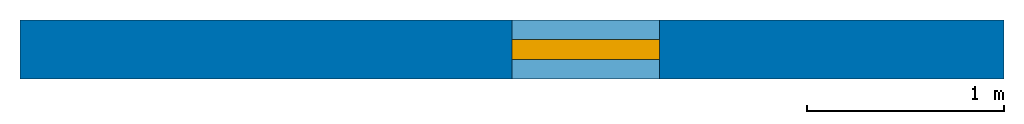
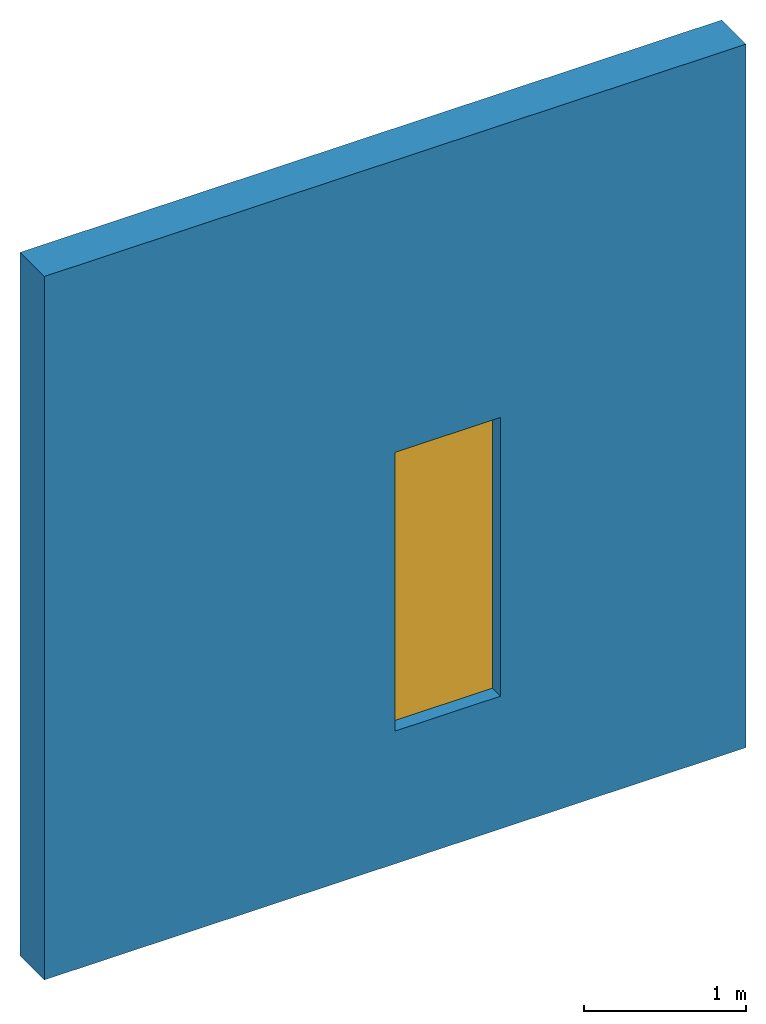
# One storey: 1 door, 1 wall, 1 opening.
"""IFC2X3 model written with IfcOpenShell, lengths in metres."""

from ifc_helpers import new_model, entity, si_unit, converted_unit, frame, origin, origin_with_axes, place, context, project, spatial, polyline, outline, extrude, material, layer, layer_set, layer_usage, element, fill, save


model = new_model("IFC2X3")

# Units and contexts
model_context = context("Model", 3, precision=1e-05, world=origin())
ifc_project = project(units=[si_unit("LENGTHUNIT", "METRE"), si_unit("AREAUNIT", "SQUARE_METRE"), si_unit("VOLUMEUNIT", "CUBIC_METRE"), converted_unit("PLANEANGLEUNIT", "DEGREE", entity("IfcPlaneAngleMeasure", 0.01745), si_unit("PLANEANGLEUNIT", "RADIAN"), dimensions=[0, 0, 0, 0, 0, 0, 0]), si_unit("SOLIDANGLEUNIT", "STERADIAN"), si_unit("MASSUNIT", "GRAM"), si_unit("TIMEUNIT", "SECOND"), si_unit("THERMODYNAMICTEMPERATUREUNIT", "DEGREE_CELSIUS"), si_unit("LUMINOUSINTENSITYUNIT", "LUMEN")], contexts=[model_context])

# Storey
placement_1 = place(None, origin_with_axes())
placement_2 = place(placement_1, origin_with_axes())
storey_placement = place(placement_2, origin_with_axes())
storey = spatial("IfcBuildingStorey", at=storey_placement, Name="Default Building Storey", CompositionType="ELEMENT", Elevation=0.0)

# Wall, opening, door
ifc_material = material(Name="simple brick material")
ifc_layer = layer(ifc_material, 0.3)
ifc_layer_set = layer_set([ifc_layer])
ifc_layer_usage = layer_usage(ifc_layer_set, "AXIS2", "POSITIVE", -0.15)
wall_placement = place(storey_placement, origin_with_axes())
wall = element("IfcWallStandardCase", 1, at=wall_placement, inside=storey, material=ifc_layer_usage, Name="Wall", context=model_context, shape_type="SweptSolid", body=[
    extrude(outline(polyline([(0.0, 0.0), (0.0, 0.3), (5.0, 0.3), (5.0, 0.0), (0.0, 0.0)])), origin_with_axes(), (0.0, 0.0, 1.0), 5.3),
])
opening_placement = place(wall_placement, frame((2.5, 0.0, 1.0), z_axis=(0.0, 0.0, 1.0), x_axis=(1.0, 0.0, 0.0)))
opening = element("IfcOpeningElement", 2, at=opening_placement, inside=storey, cuts=wall, Name="Opening Element", context=model_context, shape_type="SweptSolid", body=[
    extrude(outline(polyline([(0.0, 0.0), (0.0, 0.3), (0.75, 0.3), (0.75, 0.0), (0.0, 0.0)])), origin_with_axes(), (0.0, 0.0, 1.0), 2.1),
])
door_placement = place(opening_placement, frame((0.0, 0.1, 0.0), z_axis=(0.0, 0.0, 1.0), x_axis=(1.0, 0.0, 0.0)))
door = element("IfcDoor", 3, at=door_placement, Name="A common door", OverallHeight=2.1, OverallWidth=0.7, context=model_context, shape_type="SweptSolid", body=[
    extrude(outline(polyline([(0.0, 0.0), (0.0, 0.1), (0.75, 0.1), (0.75, 0.0), (0.0, 0.0)])), origin_with_axes(), (0.0, 0.0, 1.0), 2.1),
])
fill(opening, door)

save(model, "model.ifc")
